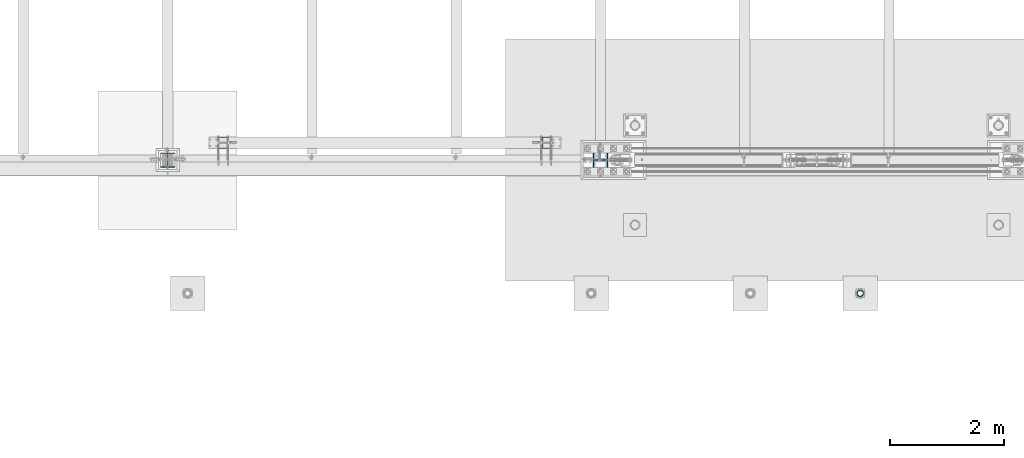
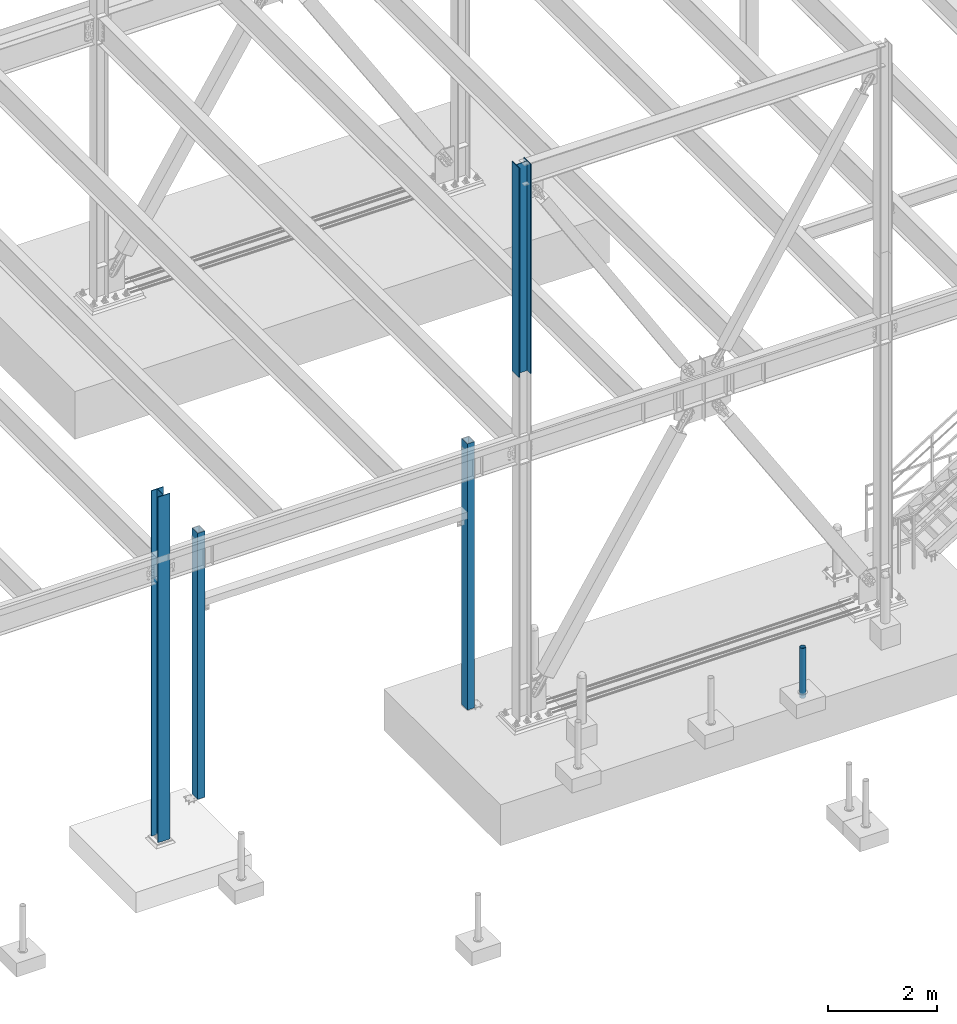
# One storey, part 1361 of 3843: 5 columns, 5 elements without a shape of their own.
"""IFC2X3 building model written with IfcOpenShell, lengths in millimetres."""

from ifc_helpers import new_model, si_unit, frame, origin_with_axes, place, context, subcontext, project, spatial, faceted_brep, material, type_object, element, aggregate, save


model = new_model("IFC2X3")

# Units and contexts
model_context = context("Model", 3, precision=1e-05, world=origin_with_axes())
body_context = subcontext(model_context, "Body", "Model", "MODEL_VIEW")
ifc_project = project(units=[si_unit("LENGTHUNIT", "METRE", prefix="MILLI"), si_unit("AREAUNIT", "SQUARE_METRE"), si_unit("VOLUMEUNIT", "CUBIC_METRE"), si_unit("MASSUNIT", "GRAM", prefix="KILO"), si_unit("TIMEUNIT", "SECOND"), si_unit("PLANEANGLEUNIT", "RADIAN"), si_unit("SOLIDANGLEUNIT", "STERADIAN"), si_unit("THERMODYNAMICTEMPERATUREUNIT", "DEGREE_CELSIUS"), si_unit("LUMINOUSINTENSITYUNIT", "LUMEN")], contexts=[model_context])

# Site, building, storey
site_placement = place(None, origin_with_axes())
site = spatial("IfcSite", under=ifc_project, at=site_placement, CompositionType="ELEMENT")
building_placement = place(site_placement, origin_with_axes())
building = spatial("IfcBuilding", under=site, at=building_placement, Name="Undefined", CompositionType="ELEMENT")
storey_placement = place(building_placement, origin_with_axes())
storey = spatial("IfcBuildingStorey", under=building, at=storey_placement, Name="Undefined", CompositionType="ELEMENT", Elevation=0.0)

# Assembly, column
assembly_1_placement = place(storey_placement, origin_with_axes())
assembly_1 = element("IfcElementAssembly", 1, at=assembly_1_placement, inside=storey, Name="PIPE_BOLLARD", AssemblyPlace="NOTDEFINED", PredefinedType="RIGID_FRAME")
ifc_material_1 = material()
column_type_1 = type_object("IfcColumnType", Name="PIPE4SCH40", PredefinedType="NOTDEFINED")
column_1_placement = place(assembly_1_placement, frame((27433.619006902, 86768.0056765079, 30378.4), z_axis=(-1.0, 0.0, 0.0), x_axis=(0.0, 0.0, 1.0)))
column_1 = element("IfcColumn", 2, at=column_1_placement, type_object=column_type_1, material=ifc_material_1, Name="PIPE_BOLLARD", ObjectType="PIPE4SCH40", context=body_context, shape_type="Brep", body=[
    faceted_brep([(0.0, -51.1301999999996, 0.0), (0.0, -48.6277098894743, 15.8001007257844), (1117.6, -48.6277098894743, 15.8001007257844), (1117.6, -51.1301999999996, 0.0), (0.0, -41.3652007257897, 30.0535775067692), (1117.6, -41.3652007257897, 30.0535775067692), (0.0, -30.0535775067647, 41.3652007257915), (1117.6, -30.0535775067647, 41.3652007257915), (0.0, -15.8001007257899, 48.6277098894789), (1117.6, -15.8001007257899, 48.6277098894789), (0.0, 0.0, 51.1301999999996), (1117.6, 0.0, 51.1301999999996), (0.0, 15.8001007257899, 48.6277098894789), (1117.6, 15.8001007257899, 48.6277098894789), (0.0, 30.0535775067647, 41.3652007257915), (1117.6, 30.0535775067647, 41.3652007257915), (0.0, 41.3652007257897, 30.0535775067692), (1117.6, 41.3652007257897, 30.0535775067692), (0.0, 48.6277098894743, 15.8001007257844), (1117.6, 48.6277098894743, 15.8001007257844), (0.0, 51.1301999999996, 0.0), (1117.6, 51.1301999999996, 0.0), (0.0, 48.6277098894743, -15.8001007257844), (1117.6, 48.6277098894743, -15.8001007257844), (0.0, 41.3652007257897, -30.0535775067692), (1117.6, 41.3652007257897, -30.0535775067692), (0.0, 30.0535775067647, -41.3652007257915), (1117.6, 30.0535775067647, -41.3652007257915), (0.0, 15.8001007257899, -48.6277098894789), (1117.6, 15.8001007257899, -48.6277098894789), (0.0, 0.0, -51.1301999999996), (1117.6, 0.0, -51.1301999999996), (0.0, -15.8001007257899, -48.6277098894789), (1117.6, -15.8001007257899, -48.6277098894789), (0.0, -30.0535775067647, -41.3652007257915), (1117.6, -30.0535775067647, -41.3652007257915), (0.0, -41.3652007257897, -30.0535775067692), (1117.6, -41.3652007257897, -30.0535775067692), (0.0, -48.6277098894743, -15.8001007257844), (1117.6, -48.6277098894743, -15.8001007257844), (0.0, -57.1499999999996, 0.0), (0.0, -54.3528799062678, -17.6603212285263), (1117.6, -54.3528799062678, -17.6603212285263), (1117.6, -57.1499999999996, 0.0), (0.0, -46.2353212285279, -33.5919271685125), (1117.6, -46.2353212285279, -33.5919271685125), (0.0, -33.5919271685152, -46.2353212285234), (1117.6, -33.5919271685152, -46.2353212285234), (0.0, -17.6603212285281, -54.3528799062624), (1117.6, -17.6603212285281, -54.3528799062624), (0.0, 0.0, -57.1499999999942), (1117.6, 0.0, -57.1499999999942), (0.0, 17.6603212285281, -54.3528799062624), (1117.6, 17.6603212285281, -54.3528799062624), (0.0, 33.5919271685152, -46.2353212285234), (1117.6, 33.5919271685152, -46.2353212285234), (0.0, 46.2353212285279, -33.5919271685125), (1117.6, 46.2353212285279, -33.5919271685125), (0.0, 54.3528799062678, -17.6603212285263), (1117.6, 54.3528799062678, -17.6603212285263), (0.0, 57.1499999999996, 0.0), (1117.6, 57.1499999999996, 0.0), (0.0, 54.3528799062678, 17.6603212285263), (1117.6, 54.3528799062678, 17.6603212285263), (0.0, 46.2353212285279, 33.5919271685125), (1117.6, 46.2353212285279, 33.5919271685125), (0.0, 33.5919271685152, 46.2353212285234), (1117.6, 33.5919271685152, 46.2353212285234), (0.0, 17.6603212285281, 54.3528799062624), (1117.6, 17.6603212285281, 54.3528799062624), (0.0, 0.0, 57.1499999999942), (1117.6, 0.0, 57.1499999999942), (0.0, -17.6603212285281, 54.3528799062624), (1117.6, -17.6603212285281, 54.3528799062624), (0.0, -33.5919271685152, 46.2353212285234), (1117.6, -33.5919271685152, 46.2353212285234), (0.0, -46.2353212285279, 33.5919271685125), (1117.6, -46.2353212285279, 33.5919271685125), (0.0, -54.3528799062678, 17.6603212285263), (1117.6, -54.3528799062678, 17.6603212285263)], [[[0, 1, 2, 3]], [[1, 4, 5, 2]], [[4, 6, 7, 5]], [[6, 8, 9, 7]], [[8, 10, 11, 9]], [[10, 12, 13, 11]], [[12, 14, 15, 13]], [[14, 16, 17, 15]], [[16, 18, 19, 17]], [[18, 20, 21, 19]], [[20, 22, 23, 21]], [[22, 24, 25, 23]], [[24, 26, 27, 25]], [[26, 28, 29, 27]], [[28, 30, 31, 29]], [[30, 32, 33, 31]], [[32, 34, 35, 33]], [[34, 36, 37, 35]], [[36, 38, 39, 37]], [[38, 0, 3, 39]], [[40, 41, 42, 43]], [[41, 44, 45, 42]], [[44, 46, 47, 45]], [[46, 48, 49, 47]], [[48, 50, 51, 49]], [[50, 52, 53, 51]], [[52, 54, 55, 53]], [[54, 56, 57, 55]], [[56, 58, 59, 57]], [[58, 60, 61, 59]], [[60, 62, 63, 61]], [[62, 64, 65, 63]], [[64, 66, 67, 65]], [[66, 68, 69, 67]], [[68, 70, 71, 69]], [[70, 72, 73, 71]], [[72, 74, 75, 73]], [[74, 76, 77, 75]], [[76, 78, 79, 77]], [[78, 40, 43, 79]], [[45, 47, 49, 51, 53, 55, 57, 59, 61, 63, 65, 67, 69, 71, 73, 75, 77, 79, 43, 42], [5, 7, 9, 11, 13, 15, 17, 19, 21, 23, 25, 27, 29, 31, 33, 35, 37, 39, 3, 2]], [[78, 76, 74, 72, 70, 68, 66, 64, 62, 60, 58, 56, 54, 52, 50, 48, 46, 44, 41, 40], [38, 36, 34, 32, 30, 28, 26, 24, 22, 20, 18, 16, 14, 12, 10, 8, 6, 4, 1, 0]]]),
])
aggregate(assembly_1, [column_1])

assembly_2_placement = place(storey_placement, origin_with_axes())
assembly_2 = element("IfcElementAssembly", 3, at=assembly_2_placement, inside=storey, Name="CB", AssemblyPlace="NOTDEFINED", PredefinedType="RIGID_FRAME")
ifc_material_2 = material(Name="STEEL/A992")
column_type_2 = type_object("IfcColumnType", Name="W10X60", PredefinedType="NOTDEFINED")
column_2_placement = place(assembly_2_placement, frame((22860.0, 89115.9, 37795.2), z_axis=(-1.0, 0.0, 0.0), x_axis=(0.0, 0.0, 1.0)))
column_2 = element("IfcColumn", 4, at=column_2_placement, type_object=column_type_2, material=ifc_material_2, Name="COLUMN", ObjectType="W10X60", context=body_context, shape_type="Brep", body=[
    faceted_brep([(0.0, 128.587499999994, -130.174999999999), (0.0, 128.587499999994, -112.712500000001), (4673.60000000001, 128.587499999994, -112.712500000001), (4673.60000000001, 128.587499999994, -130.174999999999), (0.0, 5.55624999999418, -112.712500000001), (4673.60000000001, 5.55624999999418, -112.712500000001), (0.0, 5.55624999999418, 112.712500000001), (4673.60000000001, 5.55624999999418, 112.712500000001), (0.0, 128.587499999994, 112.712500000001), (4673.60000000001, 128.587499999994, 112.712500000001), (0.0, 128.587499999994, 130.174999999999), (4673.60000000001, 128.587499999994, 130.174999999999), (0.0, -128.587499999994, 130.174999999999), (4673.60000000001, -128.587499999994, 130.174999999999), (0.0, -128.587499999994, 112.712500000001), (4673.60000000001, -128.587499999994, 112.712500000001), (0.0, -5.55624999999418, 112.712500000001), (4673.60000000001, -5.55624999999418, 112.712500000001), (0.0, -5.55624999999418, -112.712500000001), (4673.60000000001, -5.55624999999418, -112.712500000001), (0.0, -128.587499999994, -112.712500000001), (4673.60000000001, -128.587499999994, -112.712500000001), (0.0, -128.587499999994, -130.174999999999), (4673.60000000001, -128.587499999994, -130.174999999999)], [[[0, 1, 2, 3]], [[1, 4, 5, 2]], [[4, 6, 7, 5]], [[6, 8, 9, 7]], [[8, 10, 11, 9]], [[10, 12, 13, 11]], [[12, 14, 15, 13]], [[14, 16, 17, 15]], [[16, 18, 19, 17]], [[18, 20, 21, 19]], [[20, 22, 23, 21]], [[22, 0, 3, 23]], [[5, 7, 9, 11, 13, 15, 17, 19, 21, 23, 3, 2]], [[22, 20, 18, 16, 14, 12, 10, 8, 6, 4, 1, 0]]]),
])
aggregate(assembly_2, [column_2])

assembly_3_placement = place(storey_placement, origin_with_axes())
assembly_3 = element("IfcElementAssembly", 5, at=assembly_3_placement, inside=storey, Name="POST", AssemblyPlace="NOTDEFINED", PredefinedType="RIGID_FRAME")
ifc_material_3 = material()
column_type_3 = type_object("IfcColumnType", Name="HSS8X6X1/2", PredefinedType="NOTDEFINED")
column_3_placement = place(assembly_3_placement, frame((16217.9, 89420.7, 30480.0), z_axis=(0.0, 1.0, 0.0), x_axis=(0.0, 0.0, 1.0)))
column_3 = element("IfcColumn", 6, at=column_3_placement, type_object=column_type_3, material=ifc_material_3, Name="POST", ObjectType="HSS8X6X1/2", context=body_context, shape_type="Brep", body=[
    faceted_brep([(12.7000000000007, 63.5, -88.8999999999942), (12.7000000000007, -63.5, -88.8999999999942), (5949.95, -63.5, -88.8999999999942), (5949.95, 63.5, -88.8999999999942), (12.7000000000007, -63.5, 88.8999999999942), (5949.95, -63.5, 88.8999999999942), (12.7000000000007, 63.5, 88.8999999999942), (5949.95, 63.5, 88.8999999999942), (12.7000000000007, 76.2000000000007, -101.600000000006), (12.7000000000007, 76.2000000000007, 101.600000000006), (5949.95, 76.2000000000007, 101.600000000006), (5949.95, 76.2000000000007, -101.600000000006), (12.7000000000007, -76.2000000000007, 101.600000000006), (5949.95, -76.2000000000007, 101.600000000006), (12.7000000000007, -76.2000000000007, -101.600000000006), (5949.95, -76.2000000000007, -101.600000000006)], [[[0, 1, 2, 3]], [[1, 4, 5, 2]], [[4, 6, 7, 5]], [[6, 0, 3, 7]], [[8, 9, 10, 11]], [[9, 12, 13, 10]], [[12, 14, 15, 13]], [[14, 8, 11, 15]], [[13, 15, 11, 10], [5, 7, 3, 2]], [[14, 12, 9, 8], [6, 4, 1, 0]]]),
])
aggregate(assembly_3, [column_3])

assembly_4_placement = place(storey_placement, origin_with_axes())
assembly_4 = element("IfcElementAssembly", 7, at=assembly_4_placement, inside=storey, Name="POST", AssemblyPlace="NOTDEFINED", PredefinedType="RIGID_FRAME")
column_4_placement = place(assembly_4_placement, frame((21907.5, 89420.7, 30480.0), z_axis=(0.0, 1.0, 0.0), x_axis=(0.0, 0.0, 1.0)))
column_4 = element("IfcColumn", 8, at=column_4_placement, type_object=column_type_3, material=ifc_material_3, Name="POST", ObjectType="HSS8X6X1/2", context=body_context, shape_type="Brep", body=[
    faceted_brep([(12.7000000000007, 63.5, -88.8999999999942), (12.7000000000007, -63.5, -88.8999999999942), (5949.95, -63.5, -88.8999999999942), (5949.95, 63.5, -88.8999999999942), (12.7000000000007, -63.5, 88.8999999999942), (5949.95, -63.5, 88.8999999999942), (12.7000000000007, 63.5, 88.8999999999942), (5949.95, 63.5, 88.8999999999942), (12.7000000000007, 76.2000000000007, -101.600000000006), (12.7000000000007, 76.2000000000007, 101.600000000006), (5949.95, 76.2000000000007, 101.600000000006), (5949.95, 76.2000000000007, -101.600000000006), (12.7000000000007, -76.2000000000007, 101.600000000006), (5949.95, -76.2000000000007, 101.600000000006), (12.7000000000007, -76.2000000000007, -101.600000000006), (5949.95, -76.2000000000007, -101.600000000006)], [[[0, 1, 2, 3]], [[1, 4, 5, 2]], [[4, 6, 7, 5]], [[6, 0, 3, 7]], [[8, 9, 10, 11]], [[9, 12, 13, 10]], [[12, 14, 15, 13]], [[14, 8, 11, 15]], [[13, 15, 11, 10], [5, 7, 3, 2]], [[14, 12, 9, 8], [6, 4, 1, 0]]]),
])
aggregate(assembly_4, [column_4])

assembly_5_placement = place(storey_placement, origin_with_axes())
assembly_5 = element("IfcElementAssembly", 9, at=assembly_5_placement, inside=storey, Name="COLUMN", AssemblyPlace="NOTDEFINED", PredefinedType="RIGID_FRAME")
column_type_4 = type_object("IfcColumnType", Name="W10X49", PredefinedType="NOTDEFINED")
column_5_placement = place(assembly_5_placement, frame((15240.0, 89115.9, 30022.8), z_axis=(0.0, 1.0, 0.0), x_axis=(0.0, 0.0, 1.0)))
column_5 = element("IfcColumn", 10, at=column_5_placement, type_object=column_type_4, material=ifc_material_2, Name="COLUMN", ObjectType="W10X49", context=body_context, shape_type="Brep", body=[
    faceted_brep([(63.4999999999964, 127.0, -127.0), (63.4999999999964, 127.0, -112.712499999994), (7772.4, 127.0, -112.712499999994), (7772.4, 127.0, -127.0), (63.4999999999964, 3.96875, -112.7125), (7772.4, 3.96875, -112.712499999994), (63.4999999999964, 3.96875, 112.7125), (7772.4, 3.96875, 112.712499999994), (63.4999999999964, 127.0, 112.712499999994), (7772.4, 127.0, 112.712499999994), (63.4999999999964, 127.0, 127.0), (7772.4, 127.0, 127.0), (63.4999999999964, -127.0, 127.0), (7772.4, -127.0, 127.0), (63.4999999999964, -127.0, 112.712499999994), (7772.4, -127.0, 112.712499999994), (63.4999999999964, -3.96875, 112.7125), (7772.4, -3.96875, 112.712499999994), (63.4999999999964, -3.96875, -112.7125), (7772.4, -3.96875, -112.712499999994), (63.4999999999964, -127.0, -112.712499999994), (7772.4, -127.0, -112.712499999994), (63.4999999999964, -127.0, -127.0), (7772.4, -127.0, -127.0)], [[[0, 1, 2, 3]], [[1, 4, 5, 2]], [[4, 6, 7, 5]], [[6, 8, 9, 7]], [[8, 10, 11, 9]], [[10, 12, 13, 11]], [[12, 14, 15, 13]], [[14, 16, 17, 15]], [[16, 18, 19, 17]], [[18, 20, 21, 19]], [[20, 22, 23, 21]], [[22, 0, 3, 23]], [[5, 7, 9, 11, 13, 15, 17, 19, 21, 23, 3, 2]], [[22, 20, 18, 16, 14, 12, 10, 8, 6, 4, 1, 0]]]),
])
aggregate(assembly_5, [column_5])

save(model, "model.ifc")
